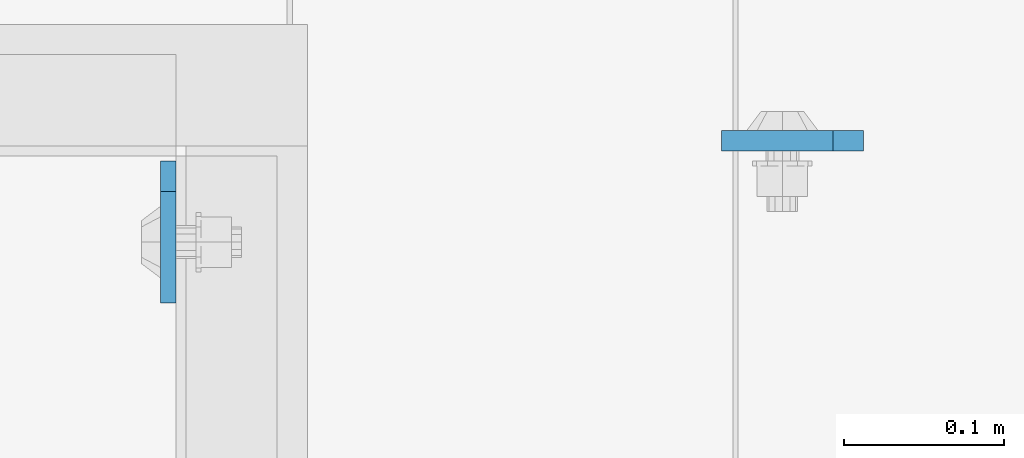
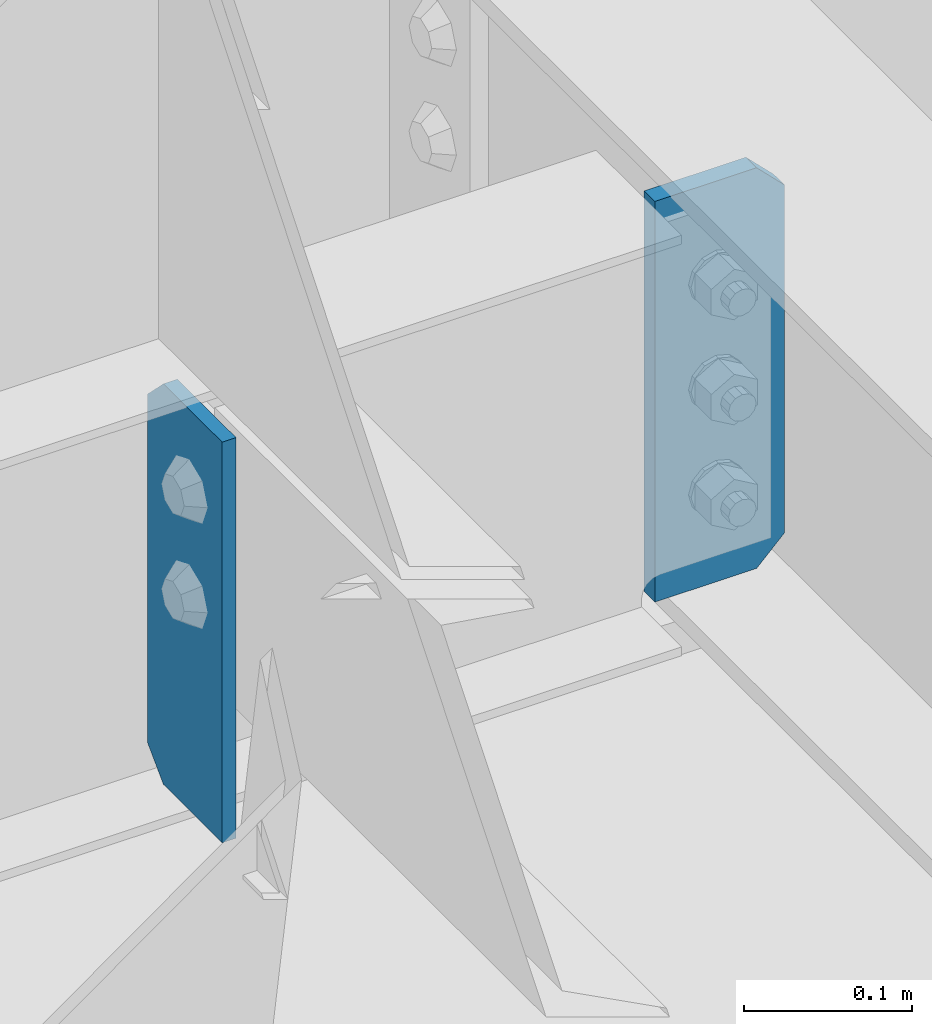
# One storey, part 1469 of 1876: 2 plates, 2 elements without a shape of their own.
"""IFC2X3 building model written with IfcOpenShell, lengths in millimetres."""

from ifc_helpers import new_model, si_unit, frame, origin_with_axes, place, context, subcontext, project, spatial, faceted_brep, material, type_object, element, aggregate, save


model = new_model("IFC2X3")

# Units and contexts
model_context = context("Model", 3, precision=1e-05, world=origin_with_axes())
body_context = subcontext(model_context, "Body", "Model", "MODEL_VIEW")
ifc_project = project(units=[si_unit("LENGTHUNIT", "METRE", prefix="MILLI"), si_unit("AREAUNIT", "SQUARE_METRE"), si_unit("VOLUMEUNIT", "CUBIC_METRE"), si_unit("MASSUNIT", "GRAM", prefix="KILO"), si_unit("TIMEUNIT", "SECOND"), si_unit("PLANEANGLEUNIT", "RADIAN"), si_unit("SOLIDANGLEUNIT", "STERADIAN"), si_unit("THERMODYNAMICTEMPERATUREUNIT", "DEGREE_CELSIUS"), si_unit("LUMINOUSINTENSITYUNIT", "LUMEN")], contexts=[model_context])

# Site, building, storey
site_placement = place(None, origin_with_axes())
site = spatial("IfcSite", under=ifc_project, at=site_placement, CompositionType="ELEMENT")
building_placement = place(site_placement, origin_with_axes())
building = spatial("IfcBuilding", under=site, at=building_placement, Name="Undefined", CompositionType="ELEMENT")
storey_placement = place(building_placement, origin_with_axes())
storey = spatial("IfcBuildingStorey", under=building, at=storey_placement, Name="Undefined", CompositionType="ELEMENT", Elevation=0.0)

# Assembly, plate
assembly_1_placement = place(storey_placement, origin_with_axes())
assembly_1 = element("IfcElementAssembly", 1, at=assembly_1_placement, inside=storey, Name="BEAM", AssemblyPlace="NOTDEFINED", PredefinedType="RIGID_FRAME")
ifc_material = material(Name="STEEL/A36")
plate_type_1 = type_object("IfcPlateType", PredefinedType="NOTDEFINED")
plate_1_placement = place(assembly_1_placement, frame((2417.7625, -5032.375, 22258.3375), z_axis=(0.0, 0.0, 1.0), x_axis=(0.0, -1.0, 0.0)))
plate_1 = element("IfcPlate", 2, at=plate_1_placement, type_object=plate_type_1, material=ifc_material, Name="PLATE", context=body_context, shape_type="Brep", body=[
    faceted_brep([(0.0, -4.76249999999982, 19.0499992370605), (0.0, -4.76249999999982, 271.462512969971), (0.0, 4.76249999999982, 271.462512969971), (0.0, 4.76249999999982, 19.0499992370605), (19.0499992370605, -4.76249999999982, 290.512512207031), (19.0499992370605, 4.76249999999982, 290.512512207031), (88.9000015258789, -4.76249999999982, 290.512512207031), (88.9000015258789, 4.76249999999982, 290.512512207031), (88.9000015258789, -4.76249999999982, 0.0), (88.9000015258789, 4.76249999999982, 0.0), (19.0499992370605, -4.76249999999982, 0.0), (19.0499992370605, 4.76249999999982, 0.0)], [[[0, 1, 2, 3]], [[1, 4, 5, 2]], [[4, 6, 7, 5]], [[6, 8, 9, 7]], [[8, 10, 11, 9]], [[10, 0, 3, 11]], [[5, 7, 9, 11, 3, 2]], [[10, 8, 6, 4, 1, 0]]]),
])
aggregate(assembly_1, [plate_1])

assembly_2_placement = place(storey_placement, origin_with_axes())
assembly_2 = element("IfcElementAssembly", 3, at=assembly_2_placement, inside=storey, Name="BEAM", AssemblyPlace="NOTDEFINED", PredefinedType="RIGID_FRAME")
plate_type_2 = type_object("IfcPlateType", PredefinedType="NOTDEFINED")
plate_2_placement = place(assembly_2_placement, frame((2853.53125, -5019.67499990463, 22251.9875), z_axis=(0.0, 0.0, 1.0), x_axis=(-1.0, 0.0, 0.0)))
plate_2 = element("IfcPlate", 4, at=plate_2_placement, type_object=plate_type_2, material=ifc_material, Name="PLATE", context=body_context, shape_type="Brep", body=[
    faceted_brep([(0.0, -6.35000000000196, 19.0499992370605), (0.0, -6.35000000000036, 271.462512969971), (0.0, 6.35000000000036, 271.462512969971), (0.0, 6.35000000000105, 19.0499992370605), (19.0499992370605, -6.35000000000036, 290.512512207031), (19.0499992370605, 6.35000000000036, 290.512512207031), (88.9000015258789, -6.35000000000036, 290.512512207031), (88.9000015258789, 6.35000000000036, 290.512512207031), (88.9000015258789, -6.34999999999991, 0.0), (88.9000015258789, 6.34999999999991, 0.0), (19.0499992370642, -6.35000000000105, 0.0), (19.0499992370633, 6.35000000000105, 0.0)], [[[0, 1, 2, 3]], [[1, 4, 5, 2]], [[4, 6, 7, 5]], [[6, 8, 9, 7]], [[8, 10, 11, 9]], [[10, 0, 3, 11]], [[5, 7, 9, 11, 3, 2]], [[10, 8, 6, 4, 1, 0]]]),
])
aggregate(assembly_2, [plate_2])

save(model, "model.ifc")
